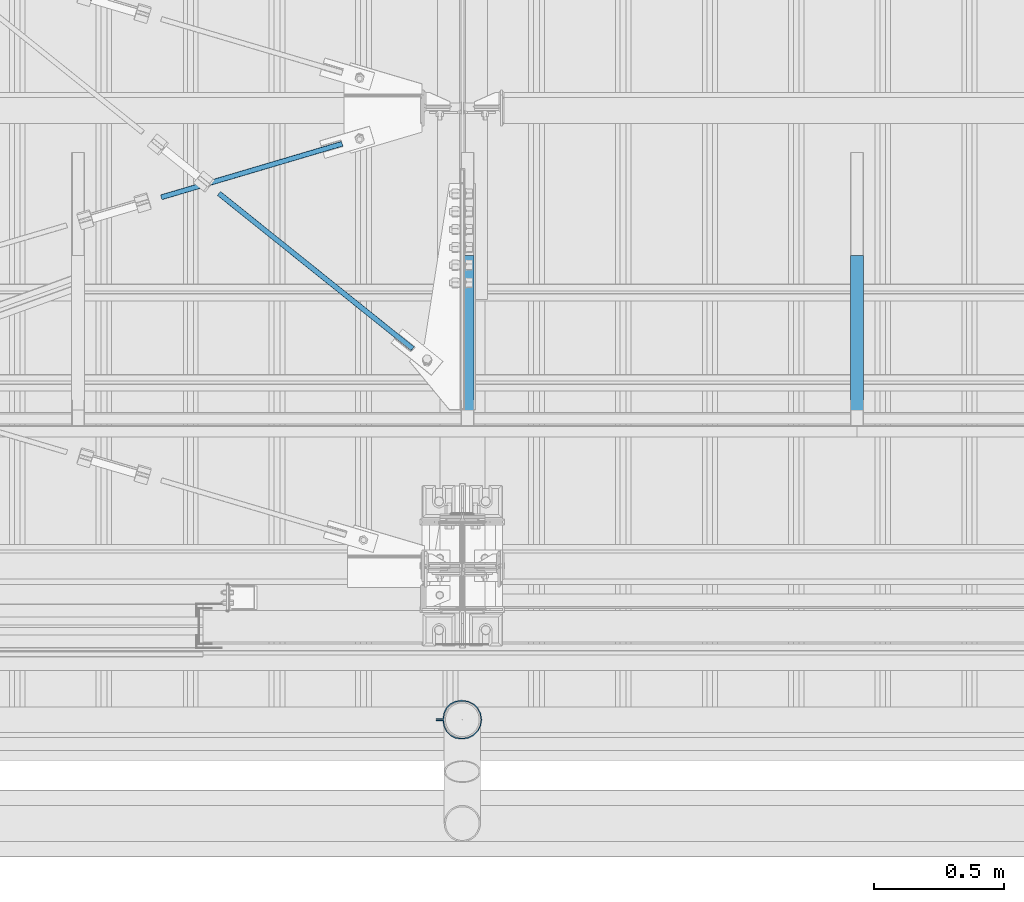
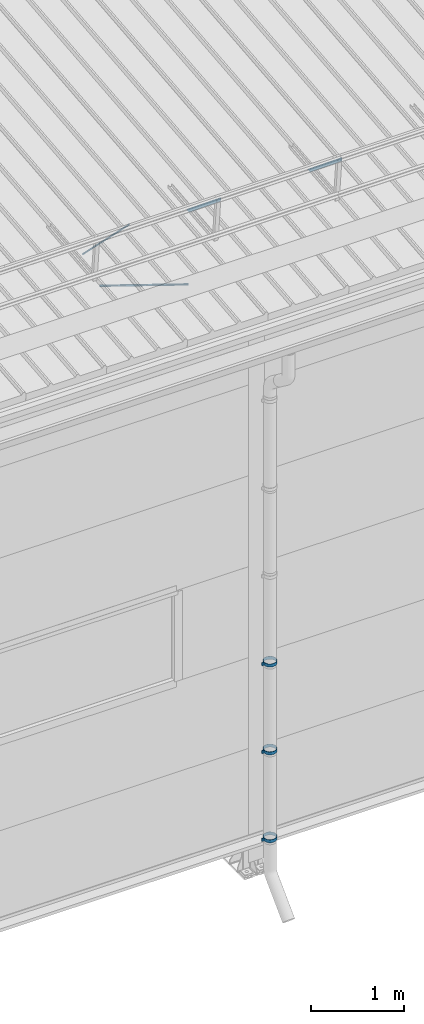
# One storey, part 293 of 709: 5 beams, 2 members, 2 openings, 7 elements without a shape of their own.
"""IFC4 building model written with IfcOpenShell, lengths in millimetres."""

from ifc_helpers import new_model, si_unit, direction, frame, origin_with_axes, place, context, subcontext, project, spatial, line, indexed_curve, outline, extrude, polygons, material, element, aggregate, save


model = new_model("IFC4")

# Units and contexts
model_context = context("Model", 3, precision=0.2, world=origin_with_axes(), true_north=direction((0.0, 1.0)))
body_context = subcontext(model_context, "Body", "Model", "MODEL_VIEW")
reference_context = subcontext(model_context, "Reference", "Model", "MODEL_VIEW")
ifc_project = project(units=[si_unit("LENGTHUNIT", "METRE", prefix="MILLI"), si_unit("AREAUNIT", "SQUARE_METRE"), si_unit("VOLUMEUNIT", "CUBIC_METRE"), si_unit("MASSUNIT", "GRAM", prefix="KILO"), si_unit("TIMEUNIT", "SECOND"), si_unit("PLANEANGLEUNIT", "RADIAN"), si_unit("SOLIDANGLEUNIT", "STERADIAN"), si_unit("THERMODYNAMICTEMPERATUREUNIT", "DEGREE_CELSIUS"), si_unit("LUMINOUSINTENSITYUNIT", "LUMEN")], contexts=[model_context])

# Site, building, storey
site_placement = place(None, origin_with_axes())
site = spatial("IfcSite", under=ifc_project, at=site_placement, CompositionType="ELEMENT")
building_placement = place(site_placement, origin_with_axes())
building = spatial("IfcBuilding", under=site, at=building_placement, Name="Undefined", CompositionType="ELEMENT")
storey_placement = place(building_placement, origin_with_axes())
storey = spatial("IfcBuildingStorey", under=building, at=storey_placement, Name="Undefined", CompositionType="ELEMENT", Elevation=0.0)

# Assembly, beam, voiding feature
assembly_1_placement = place(storey_placement, frame((8916.07962, 1724.40956, 6772.92001), z_axis=(-0.625451877, -0.7802627439, 1e-10), x_axis=(0.7742288439, -0.6206151549, 0.124123031)))
assembly_1 = element("IfcElementAssembly", 1, at=assembly_1_placement, inside=storey)
ifc_material_1 = material(Name="C355-5", Category="STEEL")
beam_1_placement = place(assembly_1_placement, origin_with_axes())
beam_1 = element("IfcBeam", 2, at=beam_1_placement, material=ifc_material_1, ObjectType="481", context=body_context, shape_type="Tessellation", body=[
    polygons([(1153.34134, -5.0, 8.66025), (1153.34134, -7.07107, 7.07107), (1153.34134, -8.66025, 5.0), (1153.34134, -9.65926, 2.58819), (1153.34134, -10.0, 0.0), (1153.34134, -9.65926, -2.58819), (1153.34134, -8.66025, -5.0), (1153.34134, -7.07107, -7.07107), (1153.34134, -5.0, -8.66025), (1153.34134, -2.58819, -9.65926), (1153.34134, 0.0, -10.0), (1153.34134, 2.58819, -9.65926), (1153.34134, 5.0, -8.66025), (1153.34134, 7.07107, -7.07107), (1153.34134, 8.66025, -5.0), (1153.34134, 9.65926, -2.58819), (1153.34134, 10.0, 0.0), (1153.34134, 9.65926, 2.58819), (1153.34134, 8.66025, 5.0), (1153.34134, 7.07107, 7.07107), (1153.34134, 5.0, 8.66025), (1153.34134, 2.58819, 9.65926), (1153.34134, 0.0, 10.0), (1153.34134, -2.58819, 9.65926), (190.0, 10.0, 0.0), (190.0, 9.65926, 2.58819), (190.0, 8.66025, 5.0), (190.0, 7.07107, 7.07107), (190.0, 5.0, 8.66025), (190.0, 2.58819, 9.65926), (190.0, 0.0, 10.0), (190.0, -2.58819, 9.65926), (190.0, -5.0, 8.66025), (190.0, -7.07107, 7.07107), (190.0, -8.66025, 5.0), (190.0, -9.65926, 2.58819), (190.0, -10.0, 0.0), (190.0, -9.65926, -2.58819), (190.0, -8.66025, -5.0), (190.0, -7.07107, -7.07107), (190.0, -5.0, -8.66025), (190.0, -2.58819, -9.65926), (190.0, 0.0, -10.0), (190.0, 2.58819, -9.65926), (190.0, 5.0, -8.66025), (190.0, 7.07107, -7.07107), (190.0, 8.66025, -5.0), (190.0, 9.65926, -2.58819), (10.0, 7.36122, 4.25), (190.0, 7.36122, 4.25), (190.0, 8.21037, 2.19996), (10.0, 8.21037, 2.19996), (10.0, 6.01041, 6.01041), (190.0, 6.01041, 6.01041), (10.0, 4.25, 7.36122), (190.0, 4.25, 7.36122), (10.0, 2.19996, 8.21037), (190.0, 2.19996, 8.21037), (10.0, 0.0, 8.5), (190.0, 0.0, 8.5), (10.0, -2.19996, 8.21037), (190.0, -2.19996, 8.21037), (10.0, -4.25, 7.36122), (190.0, -4.25, 7.36122), (10.0, -6.01041, 6.01041), (190.0, -6.01041, 6.01041), (10.0, -7.36122, 4.25), (190.0, -7.36122, 4.25), (10.0, -8.21037, 2.19996), (190.0, -8.21037, 2.19996), (10.0, -8.5, 0.0), (190.0, -8.5, 0.0), (10.0, -8.21037, -2.19996), (190.0, -8.21037, -2.19996), (10.0, -7.36122, -4.25), (190.0, -7.36122, -4.25), (10.0, -6.01041, -6.01041), (190.0, -6.01041, -6.01041), (10.0, -4.25, -7.36122), (190.0, -4.25, -7.36122), (10.0, -2.19996, -8.21037), (190.0, -2.19996, -8.21037), (10.0, 0.0, -8.5), (190.0, 0.0, -8.5), (10.0, 2.19996, -8.21037), (190.0, 2.19996, -8.21037), (10.0, 4.25, -7.36122), (190.0, 4.25, -7.36122), (10.0, 6.01041, -6.01041), (190.0, 6.01041, -6.01041), (10.0, 7.36122, -4.25), (190.0, 7.36122, -4.25), (10.0, 8.21037, -2.19996), (190.0, 8.21037, -2.19996), (10.0, 8.5, 0.0), (190.0, 8.5, 0.0)], [[[1, 2, 3, 4, 5, 6, 7, 8, 9, 10, 11, 12, 13, 14, 15, 16, 17, 18, 19, 20, 21, 22, 23, 24]], [[18, 17, 25, 26]], [[19, 18, 26, 27]], [[20, 19, 27, 28]], [[21, 20, 28, 29]], [[22, 21, 29, 30]], [[23, 22, 30, 31]], [[24, 23, 31, 32]], [[1, 24, 32, 33]], [[2, 1, 33, 34]], [[3, 2, 34, 35]], [[4, 3, 35, 36]], [[5, 4, 36, 37]], [[6, 5, 37, 38]], [[7, 6, 38, 39]], [[8, 7, 39, 40]], [[9, 8, 40, 41]], [[10, 9, 41, 42]], [[11, 10, 42, 43]], [[12, 11, 43, 44]], [[13, 12, 44, 45]], [[14, 13, 45, 46]], [[15, 14, 46, 47]], [[16, 15, 47, 48]], [[17, 16, 48, 25]], [[25, 48, 47, 46, 45, 44, 43, 42, 41, 40, 39, 38, 37, 36, 35, 34, 33, 32, 31, 30, 29, 28, 27, 26], [74, 76, 78, 80, 82, 84, 86, 88, 90, 92, 94, 96, 51, 50, 54, 56, 58, 60, 62, 64, 66, 68, 70, 72]], [[49, 50, 51, 52]], [[53, 54, 50, 49]], [[55, 56, 54, 53]], [[57, 58, 56, 55]], [[59, 60, 58, 57]], [[61, 62, 60, 59]], [[63, 64, 62, 61]], [[65, 66, 64, 63]], [[67, 68, 66, 65]], [[69, 70, 68, 67]], [[71, 72, 70, 69]], [[73, 74, 72, 71]], [[75, 76, 74, 73]], [[77, 78, 76, 75]], [[79, 80, 78, 77]], [[81, 82, 80, 79]], [[83, 84, 82, 81]], [[85, 86, 84, 83]], [[87, 88, 86, 85]], [[89, 90, 88, 87]], [[91, 92, 90, 89]], [[93, 94, 92, 91]], [[95, 96, 94, 93]], [[52, 51, 96, 95]], [[91, 89, 87, 85, 83, 81, 79, 77, 75, 73, 71, 69, 67, 65, 63, 61, 59, 57, 55, 53, 49, 52, 95, 93]]], closed=True),
])
voiding_feature_1_placement = place(beam_1_placement, frame((10.0, 0.0, 0.0), z_axis=(0.0, -1.0, 0.0), x_axis=(1.0, 0.0, 0.0)))
element("IfcVoidingFeature", 3, at=voiding_feature_1_placement, cuts=beam_1, PredefinedType="HOLE", context=reference_context, identifier="Reference", shape_type="SolidModel", body=[
    extrude(outline(indexed_curve([(10.5, 0.0), (10.14222, 2.7176), (9.09327, 5.25), (7.42462, 7.42462), (5.25, 9.09327), (2.7176, 10.14222), (0.0, 10.5), (-2.7176, 10.14222), (-5.25, 9.09327), (-7.42462, 7.42462), (-9.09327, 5.25), (-10.14222, 2.7176), (-10.5, 0.0), (-10.14222, -2.7176), (-9.09327, -5.25), (-7.42462, -7.42462), (-5.25, -9.09327), (-2.7176, -10.14222), (0.0, -10.5), (2.7176, -10.14222), (5.25, -9.09327), (7.42462, -7.42462), (9.09327, -5.25), (10.14222, -2.7176)], segments=[line(1, 2, 3, 4, 5, 6, 7, 8, 9, 10, 11, 12, 13, 14, 15, 16, 17, 18, 19, 20, 21, 22, 23, 24, 1)])), frame((0.0, 0.0, 0.0), z_axis=(-1.0, 0.0, 0.0), x_axis=(0.0, 0.0, 1.0)), (0.0, 0.0, -1.0), 180.0),
])
aggregate(assembly_1, [beam_1])

assembly_2_placement = place(storey_placement, frame((8658.15773, 1538.51229, 7290.35524), z_axis=(0.2852311229, -0.9537021177, -0.0953702118), x_axis=(0.9584587662, 0.2838155751, 0.028381558)))
assembly_2 = element("IfcElementAssembly", 4, at=assembly_2_placement, inside=storey)
beam_2_placement = place(assembly_2_placement, origin_with_axes())
beam_2 = element("IfcBeam", 5, at=beam_2_placement, material=ifc_material_1, ObjectType="569", context=body_context, shape_type="Tessellation", body=[
    polygons([(916.9749, -5.0, 8.66025), (916.9749, -7.07107, 7.07107), (916.9749, -8.66025, 5.0), (916.9749, -9.65926, 2.58819), (916.9749, -10.0, 0.0), (916.9749, -9.65926, -2.58819), (916.9749, -8.66025, -5.0), (916.9749, -7.07107, -7.07107), (916.9749, -5.0, -8.66025), (916.9749, -2.58819, -9.65926), (916.9749, 0.0, -10.0), (916.9749, 2.58819, -9.65926), (916.9749, 5.0, -8.66025), (916.9749, 7.07107, -7.07107), (916.9749, 8.66025, -5.0), (916.9749, 9.65926, -2.58819), (916.9749, 10.0, 0.0), (916.9749, 9.65926, 2.58819), (916.9749, 8.66025, 5.0), (916.9749, 7.07107, 7.07107), (916.9749, 5.0, 8.66025), (916.9749, 2.58819, 9.65926), (916.9749, 0.0, 10.0), (916.9749, -2.58819, 9.65926), (190.0, 10.0, 0.0), (190.0, 9.65926, 2.58819), (190.0, 8.66025, 5.0), (190.0, 7.07107, 7.07107), (190.0, 5.0, 8.66025), (190.0, 2.58819, 9.65926), (190.0, 0.0, 10.0), (190.0, -2.58819, 9.65926), (190.0, -5.0, 8.66025), (190.0, -7.07107, 7.07107), (190.0, -8.66025, 5.0), (190.0, -9.65926, 2.58819), (190.0, -10.0, 0.0), (190.0, -9.65926, -2.58819), (190.0, -8.66025, -5.0), (190.0, -7.07107, -7.07107), (190.0, -5.0, -8.66025), (190.0, -2.58819, -9.65926), (190.0, 0.0, -10.0), (190.0, 2.58819, -9.65926), (190.0, 5.0, -8.66025), (190.0, 7.07107, -7.07107), (190.0, 8.66025, -5.0), (190.0, 9.65926, -2.58819), (10.0, 7.36122, 4.25), (190.0, 7.36122, 4.25), (190.0, 8.21037, 2.19996), (10.0, 8.21037, 2.19996), (10.0, 6.01041, 6.01041), (190.0, 6.01041, 6.01041), (10.0, 4.25, 7.36122), (190.0, 4.25, 7.36122), (10.0, 2.19996, 8.21037), (190.0, 2.19996, 8.21037), (10.0, 0.0, 8.5), (190.0, 0.0, 8.5), (10.0, -2.19996, 8.21037), (190.0, -2.19996, 8.21037), (10.0, -4.25, 7.36122), (190.0, -4.25, 7.36122), (10.0, -6.01041, 6.01041), (190.0, -6.01041, 6.01041), (10.0, -7.36122, 4.25), (190.0, -7.36122, 4.25), (10.0, -8.21037, 2.19996), (190.0, -8.21037, 2.19996), (10.0, -8.5, 0.0), (190.0, -8.5, 0.0), (10.0, -8.21037, -2.19996), (190.0, -8.21037, -2.19996), (10.0, -7.36122, -4.25), (190.0, -7.36122, -4.25), (10.0, -6.01041, -6.01041), (190.0, -6.01041, -6.01041), (10.0, -4.25, -7.36122), (190.0, -4.25, -7.36122), (10.0, -2.19996, -8.21037), (190.0, -2.19996, -8.21037), (10.0, 0.0, -8.5), (190.0, 0.0, -8.5), (10.0, 2.19996, -8.21037), (190.0, 2.19996, -8.21037), (10.0, 4.25, -7.36122), (190.0, 4.25, -7.36122), (10.0, 6.01041, -6.01041), (190.0, 6.01041, -6.01041), (10.0, 7.36122, -4.25), (190.0, 7.36122, -4.25), (10.0, 8.21037, -2.19996), (190.0, 8.21037, -2.19996), (10.0, 8.5, 0.0), (190.0, 8.5, 0.0)], [[[1, 2, 3, 4, 5, 6, 7, 8, 9, 10, 11, 12, 13, 14, 15, 16, 17, 18, 19, 20, 21, 22, 23, 24]], [[18, 17, 25, 26]], [[19, 18, 26, 27]], [[20, 19, 27, 28]], [[21, 20, 28, 29]], [[22, 21, 29, 30]], [[23, 22, 30, 31]], [[24, 23, 31, 32]], [[1, 24, 32, 33]], [[2, 1, 33, 34]], [[3, 2, 34, 35]], [[4, 3, 35, 36]], [[5, 4, 36, 37]], [[6, 5, 37, 38]], [[7, 6, 38, 39]], [[8, 7, 39, 40]], [[9, 8, 40, 41]], [[10, 9, 41, 42]], [[11, 10, 42, 43]], [[12, 11, 43, 44]], [[13, 12, 44, 45]], [[14, 13, 45, 46]], [[15, 14, 46, 47]], [[16, 15, 47, 48]], [[17, 16, 48, 25]], [[25, 48, 47, 46, 45, 44, 43, 42, 41, 40, 39, 38, 37, 36, 35, 34, 33, 32, 31, 30, 29, 28, 27, 26], [74, 76, 78, 80, 82, 84, 86, 88, 90, 92, 94, 96, 51, 50, 54, 56, 58, 60, 62, 64, 66, 68, 70, 72]], [[49, 50, 51, 52]], [[53, 54, 50, 49]], [[55, 56, 54, 53]], [[57, 58, 56, 55]], [[59, 60, 58, 57]], [[61, 62, 60, 59]], [[63, 64, 62, 61]], [[65, 66, 64, 63]], [[67, 68, 66, 65]], [[69, 70, 68, 67]], [[71, 72, 70, 69]], [[73, 74, 72, 71]], [[75, 76, 74, 73]], [[77, 78, 76, 75]], [[79, 80, 78, 77]], [[81, 82, 80, 79]], [[83, 84, 82, 81]], [[85, 86, 84, 83]], [[87, 88, 86, 85]], [[89, 90, 88, 87]], [[91, 92, 90, 89]], [[93, 94, 92, 91]], [[95, 96, 94, 93]], [[52, 51, 96, 95]], [[91, 89, 87, 85, 83, 81, 79, 77, 75, 73, 71, 69, 67, 65, 63, 61, 59, 57, 55, 53, 49, 52, 95, 93]]], closed=True),
])
voiding_feature_2_placement = place(beam_2_placement, frame((10.0, 0.0, 0.0), z_axis=(0.0, -1.0, 0.0), x_axis=(1.0, 0.0, 0.0)))
element("IfcVoidingFeature", 6, at=voiding_feature_2_placement, cuts=beam_2, PredefinedType="HOLE", context=reference_context, identifier="Reference", shape_type="SolidModel", body=[
    extrude(outline(indexed_curve([(10.5, 0.0), (10.14222, 2.7176), (9.09327, 5.25), (7.42462, 7.42462), (5.25, 9.09327), (2.7176, 10.14222), (0.0, 10.5), (-2.7176, 10.14222), (-5.25, 9.09327), (-7.42462, 7.42462), (-9.09327, 5.25), (-10.14222, 2.7176), (-10.5, 0.0), (-10.14222, -2.7176), (-9.09327, -5.25), (-7.42462, -7.42462), (-5.25, -9.09327), (-2.7176, -10.14222), (0.0, -10.5), (2.7176, -10.14222), (5.25, -9.09327), (7.42462, -7.42462), (9.09327, -5.25), (10.14222, -2.7176)], segments=[line(1, 2, 3, 4, 5, 6, 7, 8, 9, 10, 11, 12, 13, 14, 15, 16, 17, 18, 19, 20, 21, 22, 23, 24, 1)])), frame((0.0, 0.0, 0.0), z_axis=(-1.0, 0.0, 0.0), x_axis=(0.0, 0.0, 1.0)), (0.0, 0.0, -1.0), 180.0),
])
aggregate(assembly_2, [beam_2])

# Assembly, member
assembly_3_placement = place(storey_placement, frame((10020.0, 1355.27062, 7601.48425), z_axis=(0.0, -0.6332377902, -0.7739572992), x_axis=(0.0, -0.7739572992, 0.6332377902)))
assembly_3 = element("IfcElementAssembly", 7, at=assembly_3_placement, inside=storey)
ifc_material_2 = material(Name="Steel_Undefined", Category="STEEL")
member_1_placement = place(assembly_3_placement, origin_with_axes())
member_1 = element("IfcMember", 8, at=member_1_placement, material=ifc_material_2, ObjectType="603", context=body_context, shape_type="Tessellation", body=[
    polygons([(0.0, -25.0, -20.0), (0.0, 25.0, -20.0), (848.52814, 25.0, -20.0), (848.52814, -25.0, -20.0), (40.0, 25.0, 20.0), (808.52814, 25.0, 20.0), (40.0, 22.5, 20.0), (808.52814, 22.5, 20.0), (2.5, 22.5, -17.5), (846.02814, 22.5, -17.5), (2.5, -22.5, -17.5), (846.02814, -22.5, -17.5), (40.0, -22.5, 20.0), (808.52814, -22.5, 20.0), (40.0, -25.0, 20.0), (808.52814, -25.0, 20.0)], [[[1, 2, 3, 4]], [[2, 5, 6, 3]], [[5, 7, 8, 6]], [[7, 9, 10, 8]], [[9, 11, 12, 10]], [[11, 13, 14, 12]], [[13, 15, 16, 14]], [[15, 1, 4, 16]], [[6, 8, 10, 12, 14, 16, 4, 3]], [[15, 13, 11, 9, 7, 5, 2, 1]]], closed=True),
])
aggregate(assembly_3, [member_1])

assembly_4_placement = place(storey_placement, frame((11520.0, 1355.27062, 7601.48425), z_axis=(0.0, -0.6332377902, -0.7739572992), x_axis=(0.0, -0.7739572992, 0.6332377902)))
assembly_4 = element("IfcElementAssembly", 9, at=assembly_4_placement, inside=storey)
member_2_placement = place(assembly_4_placement, origin_with_axes())
member_2 = element("IfcMember", 10, at=member_2_placement, material=ifc_material_2, ObjectType="603", context=body_context, shape_type="Tessellation", body=[
    polygons([(0.0, -25.0, -20.0), (0.0, 25.0, -20.0), (848.52814, 25.0, -20.0), (848.52814, -25.0, -20.0), (40.0, 25.0, 20.0), (808.52814, 25.0, 20.0), (40.0, 22.5, 20.0), (808.52814, 22.5, 20.0), (2.5, 22.5, -17.5), (846.02814, 22.5, -17.5), (2.5, -22.5, -17.5), (846.02814, -22.5, -17.5), (40.0, -22.5, 20.0), (808.52814, -22.5, 20.0), (40.0, -25.0, 20.0), (808.52814, -25.0, 20.0)], [[[1, 2, 3, 4]], [[2, 5, 6, 3]], [[5, 7, 8, 6]], [[7, 9, 10, 8]], [[9, 11, 12, 10]], [[11, 13, 14, 12]], [[13, 15, 16, 14]], [[15, 1, 4, 16]], [[6, 8, 10, 12, 14, 16, 4, 3]], [[15, 13, 11, 9, 7, 5, 2, 1]]], closed=True),
])
aggregate(assembly_4, [member_2])

# Assembly, beam
assembly_5_placement = place(storey_placement, frame((9899.0, -422.5, 2776.92297), z_axis=(0.0, -1.0, 0.0), x_axis=(1.0, 0.0, 0.0)))
assembly_5 = element("IfcElementAssembly", 11, at=assembly_5_placement, inside=storey)
beam_3_placement = place(assembly_5_placement, origin_with_axes())
beam_3 = element("IfcBeam", 12, at=beam_3_placement, material=ifc_material_2, ObjectType="616", context=body_context, shape_type="Tessellation", body=[
    polygons([(0.0, -20.0, 2.0), (0.0, 20.0, 2.0), (0.0, 20.0, -2.0), (0.0, -20.0, -2.0), (30.0, 20.0, -2.0), (30.0, -20.0, -2.0), (26.0, -20.0, 2.0), (26.0, 20.0, 2.0), (30.0, 20.0, 3.5), (30.0, -20.0, 3.5), (26.0, -20.0, 3.5), (26.0, 20.0, 3.5), (33.18133, 20.0, 23.5861), (33.18133, -20.0, 23.5861), (29.3771, -20.0, 24.82217), (29.3771, 20.0, 24.82217), (39.17783, -20.0, 44.05718), (39.17783, 20.0, 44.05718), (42.4139, 20.0, 41.70604), (42.4139, -20.0, 41.70604), (54.44282, -20.0, 59.32217), (54.44282, 20.0, 59.32217), (56.79396, 20.0, 56.0861), (56.79396, -20.0, 56.0861), (73.67783, -20.0, 69.1229), (73.67783, 20.0, 69.1229), (74.9139, 20.0, 65.31867), (74.9139, -20.0, 65.31867), (95.0, -20.0, 72.5), (95.0, 20.0, 72.5), (95.0, 20.0, 68.5), (95.0, -20.0, 68.5), (102.0, 20.0, 68.5), (102.0, -20.0, 68.5), (102.0, -20.0, 72.5), (102.0, 20.0, 72.5), (123.63119, 20.0, 65.07396), (123.63119, -20.0, 65.07396), (124.86726, -20.0, 68.87818), (124.86726, 20.0, 68.87818), (145.49611, -20.0, 58.36726), (145.49611, 20.0, 58.36726), (143.14497, 20.0, 55.13119), (143.14497, -20.0, 55.13119), (161.86726, -20.0, 41.99611), (161.86726, 20.0, 41.99611), (158.63119, 20.0, 39.64497), (158.63119, -20.0, 39.64497), (172.37818, -20.0, 21.36726), (172.37818, 20.0, 21.36726), (168.57396, 20.0, 20.13119), (168.57396, -20.0, 20.13119), (176.0, -20.0, -1.5), (176.0, 20.0, -1.5), (172.0, 20.0, -1.5), (172.0, -20.0, -1.5), (172.0, 20.0, -3.5), (172.0, -20.0, -3.5), (176.0, -20.0, -3.5), (176.0, 20.0, -3.5), (168.57396, 20.0, -25.13119), (168.57396, -20.0, -25.13119), (172.37818, -20.0, -26.36726), (172.37818, 20.0, -26.36726), (161.86726, -20.0, -46.99611), (161.86726, 20.0, -46.99611), (158.63119, 20.0, -44.64497), (158.63119, -20.0, -44.64497), (145.49611, -20.0, -63.36726), (145.49611, 20.0, -63.36726), (143.14497, 20.0, -60.13119), (143.14497, -20.0, -60.13119), (124.86726, -20.0, -73.87818), (124.86726, 20.0, -73.87818), (123.63119, 20.0, -70.07396), (123.63119, -20.0, -70.07396), (102.0, -20.0, -77.5), (102.0, 20.0, -77.5), (102.0, 20.0, -73.5), (102.0, -20.0, -73.5), (95.0, 20.0, -73.5), (95.0, -20.0, -73.5), (95.0, -20.0, -77.5), (95.0, 20.0, -77.5), (74.9139, 20.0, -70.31867), (74.9139, -20.0, -70.31867), (73.67783, -20.0, -74.1229), (73.67783, 20.0, -74.1229), (54.44282, -20.0, -64.32217), (54.44282, 20.0, -64.32217), (56.79396, 20.0, -61.0861), (56.79396, -20.0, -61.0861), (39.17783, -20.0, -49.05718), (39.17783, 20.0, -49.05718), (42.4139, 20.0, -46.70604), (42.4139, -20.0, -46.70604), (29.3771, -20.0, -29.82217), (29.3771, 20.0, -29.82217), (33.18133, 20.0, -28.5861), (33.18133, -20.0, -28.5861), (26.0, -20.0, -8.5), (26.0, 20.0, -8.5), (30.0, 20.0, -8.5), (30.0, -20.0, -8.5), (30.0, 20.0, -3.0), (30.0, -20.0, -3.0), (26.0, -20.0, -7.0), (26.0, 20.0, -7.0), (0.0, 20.0, -3.0), (0.0, -20.0, -3.0), (0.0, 20.0, -7.0), (0.0, -20.0, -7.0)], [[[1, 2, 3, 4]], [[4, 3, 5, 6]], [[2, 1, 7, 8]], [[6, 5, 9, 10]], [[8, 7, 11, 12]], [[10, 9, 13, 14]], [[12, 11, 15, 16]], [[15, 17, 18, 16]], [[13, 19, 20, 14]], [[17, 21, 22, 18]], [[19, 23, 24, 20]], [[21, 25, 26, 22]], [[23, 27, 28, 24]], [[25, 29, 30, 26]], [[27, 31, 32, 28]], [[32, 31, 33, 34]], [[30, 29, 35, 36]], [[34, 33, 37, 38]], [[36, 35, 39, 40]], [[39, 41, 42, 40]], [[37, 43, 44, 38]], [[41, 45, 46, 42]], [[43, 47, 48, 44]], [[45, 49, 50, 46]], [[47, 51, 52, 48]], [[49, 53, 54, 50]], [[51, 55, 56, 52]], [[56, 55, 57, 58]], [[54, 53, 59, 60]], [[58, 57, 61, 62]], [[60, 59, 63, 64]], [[63, 65, 66, 64]], [[61, 67, 68, 62]], [[65, 69, 70, 66]], [[67, 71, 72, 68]], [[69, 73, 74, 70]], [[71, 75, 76, 72]], [[73, 77, 78, 74]], [[75, 79, 80, 76]], [[80, 79, 81, 82]], [[78, 77, 83, 84]], [[82, 81, 85, 86]], [[84, 83, 87, 88]], [[87, 89, 90, 88]], [[85, 91, 92, 86]], [[89, 93, 94, 90]], [[91, 95, 96, 92]], [[93, 97, 98, 94]], [[95, 99, 100, 96]], [[97, 101, 102, 98]], [[99, 103, 104, 100]], [[104, 103, 105, 106]], [[102, 101, 107, 108]], [[106, 105, 109, 110]], [[105, 103, 99, 95, 91, 85, 81, 79, 75, 71, 67, 61, 57, 55, 51, 47, 43, 37, 33, 31, 27, 23, 19, 13, 9, 5, 3, 2, 8, 12, 16, 18, 22, 26, 30, 36, 40, 42, 46, 50, 54, 60, 64, 66, 70, 74, 78, 84, 88, 90, 94, 98, 102, 108, 111, 109]], [[108, 107, 112, 111]], [[107, 101, 97, 93, 89, 87, 83, 77, 73, 69, 65, 63, 59, 53, 49, 45, 41, 39, 35, 29, 25, 21, 17, 15, 11, 7, 1, 4, 6, 10, 14, 20, 24, 28, 32, 34, 38, 44, 48, 52, 56, 58, 62, 68, 72, 76, 80, 82, 86, 92, 96, 100, 104, 106, 110, 112]], [[111, 112, 110, 109]]], closed=True),
])
aggregate(assembly_5, [beam_3])

assembly_6_placement = place(storey_placement, frame((9899.0, -422.5, 1626.92297), z_axis=(0.0, -1.0, 0.0), x_axis=(1.0, 0.0, 0.0)))
assembly_6 = element("IfcElementAssembly", 13, at=assembly_6_placement, inside=storey)
beam_4_placement = place(assembly_6_placement, origin_with_axes())
beam_4 = element("IfcBeam", 14, at=beam_4_placement, material=ifc_material_2, ObjectType="616", context=body_context, shape_type="Tessellation", body=[
    polygons([(0.0, -20.0, 2.0), (0.0, 20.0, 2.0), (0.0, 20.0, -2.0), (0.0, -20.0, -2.0), (30.0, 20.0, -2.0), (30.0, -20.0, -2.0), (26.0, -20.0, 2.0), (26.0, 20.0, 2.0), (30.0, 20.0, 3.5), (30.0, -20.0, 3.5), (26.0, -20.0, 3.5), (26.0, 20.0, 3.5), (33.18133, 20.0, 23.5861), (33.18133, -20.0, 23.5861), (29.3771, -20.0, 24.82217), (29.3771, 20.0, 24.82217), (39.17783, -20.0, 44.05718), (39.17783, 20.0, 44.05718), (42.4139, 20.0, 41.70604), (42.4139, -20.0, 41.70604), (54.44282, -20.0, 59.32217), (54.44282, 20.0, 59.32217), (56.79396, 20.0, 56.0861), (56.79396, -20.0, 56.0861), (73.67783, -20.0, 69.1229), (73.67783, 20.0, 69.1229), (74.9139, 20.0, 65.31867), (74.9139, -20.0, 65.31867), (95.0, -20.0, 72.5), (95.0, 20.0, 72.5), (95.0, 20.0, 68.5), (95.0, -20.0, 68.5), (102.0, 20.0, 68.5), (102.0, -20.0, 68.5), (102.0, -20.0, 72.5), (102.0, 20.0, 72.5), (123.63119, 20.0, 65.07396), (123.63119, -20.0, 65.07396), (124.86726, -20.0, 68.87818), (124.86726, 20.0, 68.87818), (145.49611, -20.0, 58.36726), (145.49611, 20.0, 58.36726), (143.14497, 20.0, 55.13119), (143.14497, -20.0, 55.13119), (161.86726, -20.0, 41.99611), (161.86726, 20.0, 41.99611), (158.63119, 20.0, 39.64497), (158.63119, -20.0, 39.64497), (172.37818, -20.0, 21.36726), (172.37818, 20.0, 21.36726), (168.57396, 20.0, 20.13119), (168.57396, -20.0, 20.13119), (176.0, -20.0, -1.5), (176.0, 20.0, -1.5), (172.0, 20.0, -1.5), (172.0, -20.0, -1.5), (172.0, 20.0, -3.5), (172.0, -20.0, -3.5), (176.0, -20.0, -3.5), (176.0, 20.0, -3.5), (168.57396, 20.0, -25.13119), (168.57396, -20.0, -25.13119), (172.37818, -20.0, -26.36726), (172.37818, 20.0, -26.36726), (161.86726, -20.0, -46.99611), (161.86726, 20.0, -46.99611), (158.63119, 20.0, -44.64497), (158.63119, -20.0, -44.64497), (145.49611, -20.0, -63.36726), (145.49611, 20.0, -63.36726), (143.14497, 20.0, -60.13119), (143.14497, -20.0, -60.13119), (124.86726, -20.0, -73.87818), (124.86726, 20.0, -73.87818), (123.63119, 20.0, -70.07396), (123.63119, -20.0, -70.07396), (102.0, -20.0, -77.5), (102.0, 20.0, -77.5), (102.0, 20.0, -73.5), (102.0, -20.0, -73.5), (95.0, 20.0, -73.5), (95.0, -20.0, -73.5), (95.0, -20.0, -77.5), (95.0, 20.0, -77.5), (74.9139, 20.0, -70.31867), (74.9139, -20.0, -70.31867), (73.67783, -20.0, -74.1229), (73.67783, 20.0, -74.1229), (54.44282, -20.0, -64.32217), (54.44282, 20.0, -64.32217), (56.79396, 20.0, -61.0861), (56.79396, -20.0, -61.0861), (39.17783, -20.0, -49.05718), (39.17783, 20.0, -49.05718), (42.4139, 20.0, -46.70604), (42.4139, -20.0, -46.70604), (29.3771, -20.0, -29.82217), (29.3771, 20.0, -29.82217), (33.18133, 20.0, -28.5861), (33.18133, -20.0, -28.5861), (26.0, -20.0, -8.5), (26.0, 20.0, -8.5), (30.0, 20.0, -8.5), (30.0, -20.0, -8.5), (30.0, 20.0, -3.0), (30.0, -20.0, -3.0), (26.0, -20.0, -7.0), (26.0, 20.0, -7.0), (0.0, 20.0, -3.0), (0.0, -20.0, -3.0), (0.0, 20.0, -7.0), (0.0, -20.0, -7.0)], [[[1, 2, 3, 4]], [[4, 3, 5, 6]], [[2, 1, 7, 8]], [[6, 5, 9, 10]], [[8, 7, 11, 12]], [[10, 9, 13, 14]], [[12, 11, 15, 16]], [[15, 17, 18, 16]], [[13, 19, 20, 14]], [[17, 21, 22, 18]], [[19, 23, 24, 20]], [[21, 25, 26, 22]], [[23, 27, 28, 24]], [[25, 29, 30, 26]], [[27, 31, 32, 28]], [[32, 31, 33, 34]], [[30, 29, 35, 36]], [[34, 33, 37, 38]], [[36, 35, 39, 40]], [[39, 41, 42, 40]], [[37, 43, 44, 38]], [[41, 45, 46, 42]], [[43, 47, 48, 44]], [[45, 49, 50, 46]], [[47, 51, 52, 48]], [[49, 53, 54, 50]], [[51, 55, 56, 52]], [[56, 55, 57, 58]], [[54, 53, 59, 60]], [[58, 57, 61, 62]], [[60, 59, 63, 64]], [[63, 65, 66, 64]], [[61, 67, 68, 62]], [[65, 69, 70, 66]], [[67, 71, 72, 68]], [[69, 73, 74, 70]], [[71, 75, 76, 72]], [[73, 77, 78, 74]], [[75, 79, 80, 76]], [[80, 79, 81, 82]], [[78, 77, 83, 84]], [[82, 81, 85, 86]], [[84, 83, 87, 88]], [[87, 89, 90, 88]], [[85, 91, 92, 86]], [[89, 93, 94, 90]], [[91, 95, 96, 92]], [[93, 97, 98, 94]], [[95, 99, 100, 96]], [[97, 101, 102, 98]], [[99, 103, 104, 100]], [[104, 103, 105, 106]], [[102, 101, 107, 108]], [[106, 105, 109, 110]], [[105, 103, 99, 95, 91, 85, 81, 79, 75, 71, 67, 61, 57, 55, 51, 47, 43, 37, 33, 31, 27, 23, 19, 13, 9, 5, 3, 2, 8, 12, 16, 18, 22, 26, 30, 36, 40, 42, 46, 50, 54, 60, 64, 66, 70, 74, 78, 84, 88, 90, 94, 98, 102, 108, 111, 109]], [[108, 107, 112, 111]], [[107, 101, 97, 93, 89, 87, 83, 77, 73, 69, 65, 63, 59, 53, 49, 45, 41, 39, 35, 29, 25, 21, 17, 15, 11, 7, 1, 4, 6, 10, 14, 20, 24, 28, 32, 34, 38, 44, 48, 52, 56, 58, 62, 68, 72, 76, 80, 82, 86, 92, 96, 100, 104, 106, 110, 112]], [[111, 112, 110, 109]]], closed=True),
])
aggregate(assembly_6, [beam_4])

assembly_7_placement = place(storey_placement, frame((9899.0, -422.5, 476.92297), z_axis=(0.0, -1.0, 0.0), x_axis=(1.0, 0.0, 0.0)))
assembly_7 = element("IfcElementAssembly", 15, at=assembly_7_placement, inside=storey)
beam_5_placement = place(assembly_7_placement, origin_with_axes())
beam_5 = element("IfcBeam", 16, at=beam_5_placement, material=ifc_material_2, ObjectType="616", context=body_context, shape_type="Tessellation", body=[
    polygons([(0.0, -20.0, 2.0), (0.0, 20.0, 2.0), (0.0, 20.0, -2.0), (0.0, -20.0, -2.0), (30.0, 20.0, -2.0), (30.0, -20.0, -2.0), (26.0, -20.0, 2.0), (26.0, 20.0, 2.0), (30.0, 20.0, 3.5), (30.0, -20.0, 3.5), (26.0, -20.0, 3.5), (26.0, 20.0, 3.5), (33.18133, 20.0, 23.5861), (33.18133, -20.0, 23.5861), (29.3771, -20.0, 24.82217), (29.3771, 20.0, 24.82217), (39.17783, -20.0, 44.05718), (39.17783, 20.0, 44.05718), (42.4139, 20.0, 41.70604), (42.4139, -20.0, 41.70604), (54.44282, -20.0, 59.32217), (54.44282, 20.0, 59.32217), (56.79396, 20.0, 56.0861), (56.79396, -20.0, 56.0861), (73.67783, -20.0, 69.1229), (73.67783, 20.0, 69.1229), (74.9139, 20.0, 65.31867), (74.9139, -20.0, 65.31867), (95.0, -20.0, 72.5), (95.0, 20.0, 72.5), (95.0, 20.0, 68.5), (95.0, -20.0, 68.5), (102.0, 20.0, 68.5), (102.0, -20.0, 68.5), (102.0, -20.0, 72.5), (102.0, 20.0, 72.5), (123.63119, 20.0, 65.07396), (123.63119, -20.0, 65.07396), (124.86726, -20.0, 68.87818), (124.86726, 20.0, 68.87818), (145.49611, -20.0, 58.36726), (145.49611, 20.0, 58.36726), (143.14497, 20.0, 55.13119), (143.14497, -20.0, 55.13119), (161.86726, -20.0, 41.99611), (161.86726, 20.0, 41.99611), (158.63119, 20.0, 39.64497), (158.63119, -20.0, 39.64497), (172.37818, -20.0, 21.36726), (172.37818, 20.0, 21.36726), (168.57396, 20.0, 20.13119), (168.57396, -20.0, 20.13119), (176.0, -20.0, -1.5), (176.0, 20.0, -1.5), (172.0, 20.0, -1.5), (172.0, -20.0, -1.5), (172.0, 20.0, -3.5), (172.0, -20.0, -3.5), (176.0, -20.0, -3.5), (176.0, 20.0, -3.5), (168.57396, 20.0, -25.13119), (168.57396, -20.0, -25.13119), (172.37818, -20.0, -26.36726), (172.37818, 20.0, -26.36726), (161.86726, -20.0, -46.99611), (161.86726, 20.0, -46.99611), (158.63119, 20.0, -44.64497), (158.63119, -20.0, -44.64497), (145.49611, -20.0, -63.36726), (145.49611, 20.0, -63.36726), (143.14497, 20.0, -60.13119), (143.14497, -20.0, -60.13119), (124.86726, -20.0, -73.87818), (124.86726, 20.0, -73.87818), (123.63119, 20.0, -70.07396), (123.63119, -20.0, -70.07396), (102.0, -20.0, -77.5), (102.0, 20.0, -77.5), (102.0, 20.0, -73.5), (102.0, -20.0, -73.5), (95.0, 20.0, -73.5), (95.0, -20.0, -73.5), (95.0, -20.0, -77.5), (95.0, 20.0, -77.5), (74.9139, 20.0, -70.31867), (74.9139, -20.0, -70.31867), (73.67783, -20.0, -74.1229), (73.67783, 20.0, -74.1229), (54.44282, -20.0, -64.32217), (54.44282, 20.0, -64.32217), (56.79396, 20.0, -61.0861), (56.79396, -20.0, -61.0861), (39.17783, -20.0, -49.05718), (39.17783, 20.0, -49.05718), (42.4139, 20.0, -46.70604), (42.4139, -20.0, -46.70604), (29.3771, -20.0, -29.82217), (29.3771, 20.0, -29.82217), (33.18133, 20.0, -28.5861), (33.18133, -20.0, -28.5861), (26.0, -20.0, -8.5), (26.0, 20.0, -8.5), (30.0, 20.0, -8.5), (30.0, -20.0, -8.5), (30.0, 20.0, -3.0), (30.0, -20.0, -3.0), (26.0, -20.0, -7.0), (26.0, 20.0, -7.0), (0.0, 20.0, -3.0), (0.0, -20.0, -3.0), (0.0, 20.0, -7.0), (0.0, -20.0, -7.0)], [[[1, 2, 3, 4]], [[4, 3, 5, 6]], [[2, 1, 7, 8]], [[6, 5, 9, 10]], [[8, 7, 11, 12]], [[10, 9, 13, 14]], [[12, 11, 15, 16]], [[15, 17, 18, 16]], [[13, 19, 20, 14]], [[17, 21, 22, 18]], [[19, 23, 24, 20]], [[21, 25, 26, 22]], [[23, 27, 28, 24]], [[25, 29, 30, 26]], [[27, 31, 32, 28]], [[32, 31, 33, 34]], [[30, 29, 35, 36]], [[34, 33, 37, 38]], [[36, 35, 39, 40]], [[39, 41, 42, 40]], [[37, 43, 44, 38]], [[41, 45, 46, 42]], [[43, 47, 48, 44]], [[45, 49, 50, 46]], [[47, 51, 52, 48]], [[49, 53, 54, 50]], [[51, 55, 56, 52]], [[56, 55, 57, 58]], [[54, 53, 59, 60]], [[58, 57, 61, 62]], [[60, 59, 63, 64]], [[63, 65, 66, 64]], [[61, 67, 68, 62]], [[65, 69, 70, 66]], [[67, 71, 72, 68]], [[69, 73, 74, 70]], [[71, 75, 76, 72]], [[73, 77, 78, 74]], [[75, 79, 80, 76]], [[80, 79, 81, 82]], [[78, 77, 83, 84]], [[82, 81, 85, 86]], [[84, 83, 87, 88]], [[87, 89, 90, 88]], [[85, 91, 92, 86]], [[89, 93, 94, 90]], [[91, 95, 96, 92]], [[93, 97, 98, 94]], [[95, 99, 100, 96]], [[97, 101, 102, 98]], [[99, 103, 104, 100]], [[104, 103, 105, 106]], [[102, 101, 107, 108]], [[106, 105, 109, 110]], [[105, 103, 99, 95, 91, 85, 81, 79, 75, 71, 67, 61, 57, 55, 51, 47, 43, 37, 33, 31, 27, 23, 19, 13, 9, 5, 3, 2, 8, 12, 16, 18, 22, 26, 30, 36, 40, 42, 46, 50, 54, 60, 64, 66, 70, 74, 78, 84, 88, 90, 94, 98, 102, 108, 111, 109]], [[108, 107, 112, 111]], [[107, 101, 97, 93, 89, 87, 83, 77, 73, 69, 65, 63, 59, 53, 49, 45, 41, 39, 35, 29, 25, 21, 17, 15, 11, 7, 1, 4, 6, 10, 14, 20, 24, 28, 32, 34, 38, 44, 48, 52, 56, 58, 62, 68, 72, 76, 80, 82, 86, 92, 96, 100, 104, 106, 110, 112]], [[111, 112, 110, 109]]], closed=True),
])
aggregate(assembly_7, [beam_5])

save(model, "model.ifc")
